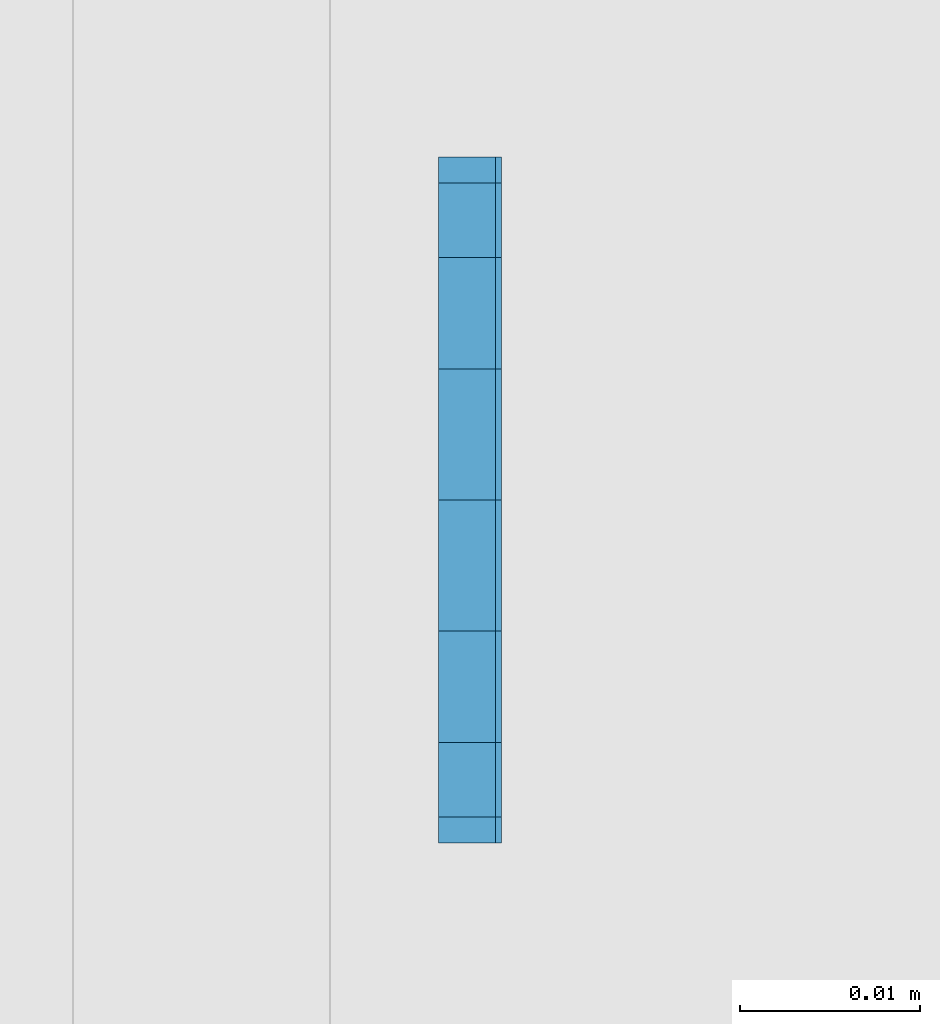
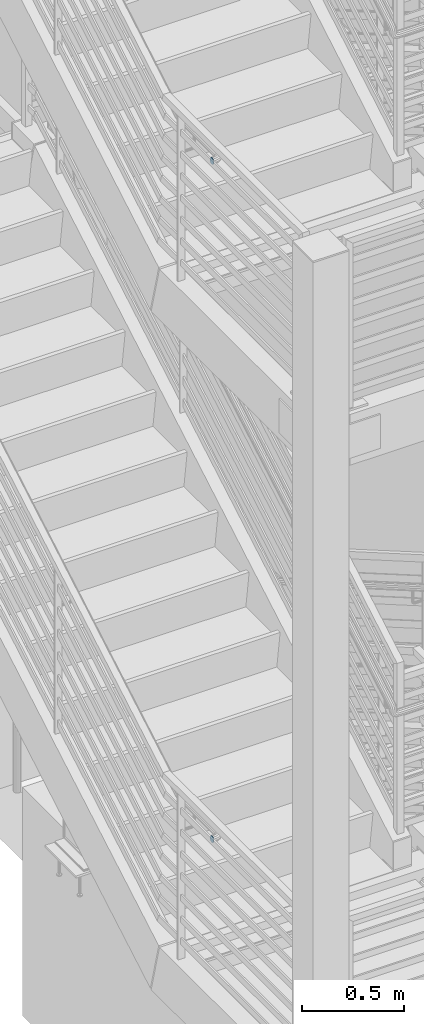
# One storey, part 1122 of 1179: 2 plates, 2 elements without a shape of their own.
"""IFC2X3 building model written with IfcOpenShell, lengths in millimetres."""

from ifc_helpers import new_model, si_unit, frame, origin_with_axes, place, context, subcontext, project, spatial, faceted_brep, material, type_object, element, aggregate, save


model = new_model("IFC2X3")

# Units and contexts
model_context = context("Model", 3, precision=1e-05, world=origin_with_axes())
body_context = subcontext(model_context, "Body", "Model", "MODEL_VIEW")
ifc_project = project(units=[si_unit("LENGTHUNIT", "METRE", prefix="MILLI"), si_unit("AREAUNIT", "SQUARE_METRE"), si_unit("VOLUMEUNIT", "CUBIC_METRE"), si_unit("MASSUNIT", "GRAM", prefix="KILO"), si_unit("TIMEUNIT", "SECOND"), si_unit("PLANEANGLEUNIT", "RADIAN"), si_unit("SOLIDANGLEUNIT", "STERADIAN"), si_unit("THERMODYNAMICTEMPERATUREUNIT", "DEGREE_CELSIUS"), si_unit("LUMINOUSINTENSITYUNIT", "LUMEN")], contexts=[model_context])

# Site, building, storey
site_placement = place(None, origin_with_axes())
site = spatial("IfcSite", under=ifc_project, at=site_placement, CompositionType="ELEMENT")
building_placement = place(site_placement, origin_with_axes())
building = spatial("IfcBuilding", under=site, at=building_placement, Name="Undefined", CompositionType="ELEMENT")
storey_placement = place(building_placement, origin_with_axes())
storey = spatial("IfcBuildingStorey", under=building, at=storey_placement, Name="Undefined", CompositionType="ELEMENT", Elevation=0.0)

# Assembly, plate
assembly_1_placement = place(storey_placement, origin_with_axes())
assembly_1 = element("IfcElementAssembly", 1, at=assembly_1_placement, inside=storey, Name="GUARDRAIL", AssemblyPlace="NOTDEFINED", PredefinedType="RIGID_FRAME")
ifc_material = material(Name="STEEL/A36")
plate_type = type_object("IfcPlateType", PredefinedType="NOTDEFINED")
plate_1_placement = place(assembly_1_placement, frame((-3230.56250000055, 31159.4500011095, 3051.1750000093), z_axis=(0.0, 1.0, 0.0), x_axis=(0.0, 0.0, -1.0)))
plate_1 = element("IfcPlate", 2, at=plate_1_placement, type_object=plate_type, material=ifc_material, Name="PLATE", context=body_context, shape_type="Brep", body=[
    faceted_brep([(0.0, -1.58750000000146, 19.0499992370605), (1.4500948475843, -1.58750000000146, 26.3401198575302), (1.4500948475843, 1.58750000000146, 26.3401198575302), (0.0, 1.58750000000146, 19.0499992370605), (5.57961559493651, -1.58750000000146, 32.5203844050629), (5.57961559493651, 1.58750000000146, 32.5203844050629), (11.7598801424701, -1.58750000000146, 36.6499051524152), (11.7598801424701, 1.58750000000146, 36.6499051524152), (19.0500007629398, -1.58750000000146, 38.0999999999985), (19.0500007629398, 1.58750000000146, 38.0999999999985), (26.3401198575302, -1.58750000000146, 36.6499051524152), (26.3401198575302, 1.58750000000146, 36.6499051524152), (32.5203844050639, -1.58750000000146, 32.5203844050629), (32.5203844050639, 1.58750000000146, 32.5203844050629), (36.6499051524161, -1.58750000000146, 26.3401198575302), (36.6499051524161, 1.58750000000146, 26.3401198575302), (38.1000000000004, -1.58750000000146, 19.0499992370605), (38.1000000000004, 1.58750000000146, 19.0499992370605), (36.6499051524161, -1.58750000000146, 11.7598801424683), (36.6499051524161, 1.58750000000146, 11.7598801424683), (32.5203844050639, -1.58750000000146, 5.5796155949356), (32.5203844050639, 1.58750000000146, 5.5796155949356), (26.3401198575302, -1.58750000000146, 1.45009484758339), (26.3401198575302, 1.58750000000146, 1.45009484758339), (19.0499992370605, -1.58750000000146, 0.0), (19.0499992370605, 1.58750000000146, 0.0), (11.7598801424701, -1.58750000000146, 1.45009484758339), (11.7598801424701, 1.58750000000146, 1.45009484758339), (5.57961559493651, -1.58750000000146, 5.5796155949356), (5.57961559493651, 1.58750000000146, 5.5796155949356), (1.4500948475843, -1.58750000000146, 11.7598801424683), (1.4500948475843, 1.58750000000146, 11.7598801424683)], [[[0, 1, 2, 3]], [[1, 4, 5, 2]], [[4, 6, 7, 5]], [[6, 8, 9, 7]], [[8, 10, 11, 9]], [[10, 12, 13, 11]], [[12, 14, 15, 13]], [[14, 16, 17, 15]], [[16, 18, 19, 17]], [[18, 20, 21, 19]], [[20, 22, 23, 21]], [[22, 24, 25, 23]], [[24, 26, 27, 25]], [[26, 28, 29, 27]], [[28, 30, 31, 29]], [[30, 0, 3, 31]], [[5, 7, 9, 11, 13, 15, 17, 19, 21, 23, 25, 27, 29, 31, 3, 2]], [[30, 28, 26, 24, 22, 20, 18, 16, 14, 12, 10, 8, 6, 4, 1, 0]]]),
])
aggregate(assembly_1, [plate_1])

assembly_2_placement = place(storey_placement, origin_with_axes())
assembly_2 = element("IfcElementAssembly", 3, at=assembly_2_placement, inside=storey, Name="GUARDRAIL", AssemblyPlace="NOTDEFINED", PredefinedType="RIGID_FRAME")
plate_2_placement = place(assembly_2_placement, frame((-3230.88000076555, 31159.4500027519, 7124.69999999552), z_axis=(0.0, 1.0, 0.0), x_axis=(0.0, 0.0, -1.0)))
plate_2 = element("IfcPlate", 4, at=plate_2_placement, type_object=plate_type, material=ifc_material, Name="PLATE", context=body_context, shape_type="Brep", body=[
    faceted_brep([(0.0, -1.58750000000146, 19.0499992370605), (1.4500948475843, -1.58750000000146, 26.3401198575302), (1.4500948475843, 1.58750000000146, 26.3401198575302), (0.0, 1.58750000000146, 19.0499992370605), (5.57961559493651, -1.58750000000146, 32.5203844050629), (5.57961559493651, 1.58750000000146, 32.5203844050629), (11.7598801424701, -1.58750000000146, 36.6499051524152), (11.7598801424701, 1.58750000000146, 36.6499051524152), (19.0500007629398, -1.58750000000146, 38.0999999999985), (19.0500007629398, 1.58750000000146, 38.0999999999985), (26.3401198575302, -1.58750000000146, 36.6499051524152), (26.3401198575302, 1.58750000000146, 36.6499051524152), (32.5203844050639, -1.58750000000146, 32.5203844050629), (32.5203844050639, 1.58750000000146, 32.5203844050629), (36.6499051524161, -1.58750000000146, 26.3401198575302), (36.6499051524161, 1.58750000000146, 26.3401198575302), (38.1000000000004, -1.58750000000146, 19.0499992370605), (38.1000000000004, 1.58750000000146, 19.0499992370605), (36.6499051524161, -1.58750000000146, 11.7598801424683), (36.6499051524161, 1.58750000000146, 11.7598801424683), (32.5203844050639, -1.58750000000146, 5.5796155949356), (32.5203844050639, 1.58750000000146, 5.5796155949356), (26.3401198575302, -1.58750000000146, 1.45009484758339), (26.3401198575302, 1.58750000000146, 1.45009484758339), (19.0499992370605, -1.58750000000146, 0.0), (19.0499992370605, 1.58750000000146, 0.0), (11.7598801424701, -1.58750000000146, 1.45009484758339), (11.7598801424701, 1.58750000000146, 1.45009484758339), (5.57961559493651, -1.58750000000146, 5.5796155949356), (5.57961559493651, 1.58750000000146, 5.5796155949356), (1.4500948475843, -1.58750000000146, 11.7598801424683), (1.4500948475843, 1.58750000000146, 11.7598801424683)], [[[0, 1, 2, 3]], [[1, 4, 5, 2]], [[4, 6, 7, 5]], [[6, 8, 9, 7]], [[8, 10, 11, 9]], [[10, 12, 13, 11]], [[12, 14, 15, 13]], [[14, 16, 17, 15]], [[16, 18, 19, 17]], [[18, 20, 21, 19]], [[20, 22, 23, 21]], [[22, 24, 25, 23]], [[24, 26, 27, 25]], [[26, 28, 29, 27]], [[28, 30, 31, 29]], [[30, 0, 3, 31]], [[5, 7, 9, 11, 13, 15, 17, 19, 21, 23, 25, 27, 29, 31, 3, 2]], [[30, 28, 26, 24, 22, 20, 18, 16, 14, 12, 10, 8, 6, 4, 1, 0]]]),
])
aggregate(assembly_2, [plate_2])

save(model, "model.ifc")
